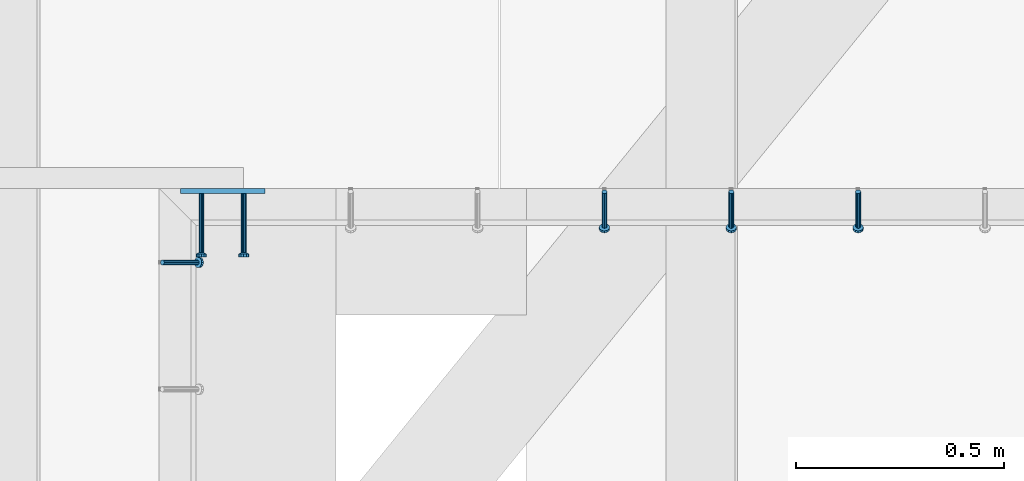
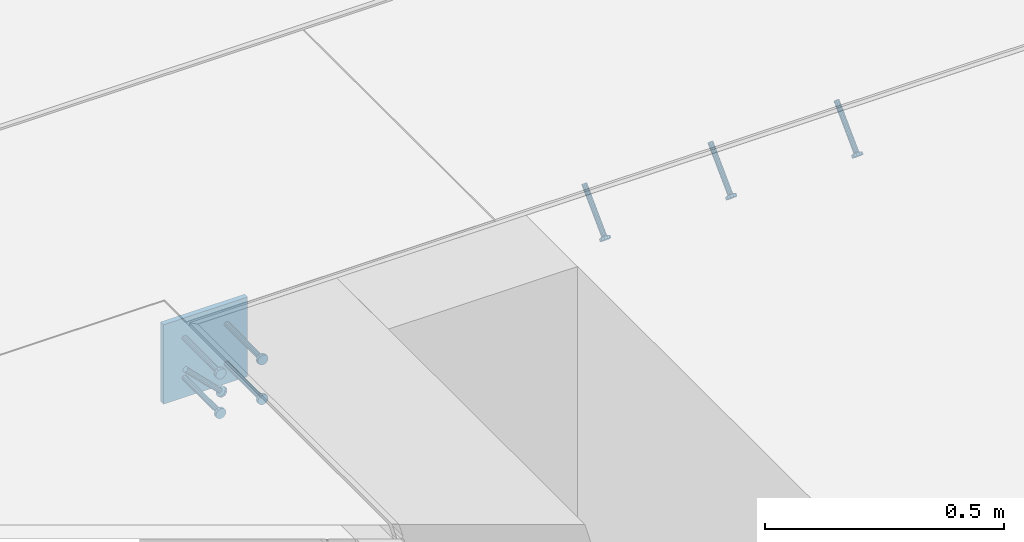
# One storey, part 2517 of 3843: 5 beams, 4 members, 3 elements without a shape of their own.
"""IFC2X3 building model written with IfcOpenShell, lengths in millimetres."""

from ifc_helpers import new_model, si_unit, frame, origin_with_axes, place, context, subcontext, project, spatial, faceted_brep, material, type_object, element, aggregate, save


model = new_model("IFC2X3")

# Units and contexts
model_context = context("Model", 3, precision=1e-05, world=origin_with_axes())
body_context = subcontext(model_context, "Body", "Model", "MODEL_VIEW")
ifc_project = project(units=[si_unit("LENGTHUNIT", "METRE", prefix="MILLI"), si_unit("AREAUNIT", "SQUARE_METRE"), si_unit("VOLUMEUNIT", "CUBIC_METRE"), si_unit("MASSUNIT", "GRAM", prefix="KILO"), si_unit("TIMEUNIT", "SECOND"), si_unit("PLANEANGLEUNIT", "RADIAN"), si_unit("SOLIDANGLEUNIT", "STERADIAN"), si_unit("THERMODYNAMICTEMPERATUREUNIT", "DEGREE_CELSIUS"), si_unit("LUMINOUSINTENSITYUNIT", "LUMEN")], contexts=[model_context])

# Site, building, storey
site_placement = place(None, origin_with_axes())
site = spatial("IfcSite", under=ifc_project, at=site_placement, CompositionType="ELEMENT")
building_placement = place(site_placement, origin_with_axes())
building = spatial("IfcBuilding", under=site, at=building_placement, Name="Undefined", CompositionType="ELEMENT")
storey_placement = place(building_placement, origin_with_axes())
storey = spatial("IfcBuildingStorey", under=building, at=storey_placement, Name="Undefined", CompositionType="ELEMENT", Elevation=0.0)

# Assembly, members
assembly_1_placement = place(storey_placement, origin_with_axes())
assembly_1 = element("IfcElementAssembly", 1, at=assembly_1_placement, inside=storey, Name="EMBED_ANGLE", AssemblyPlace="NOTDEFINED", PredefinedType="RIGID_FRAME")
ifc_material_1 = material(Name="STEEL/A108")
member_type = type_object("IfcMemberType", PredefinedType="NOTDEFINED")
member_1_placement = place(assembly_1_placement, frame((61332.250304107, 90041.2848125, 30446.6625), z_axis=(-1.0, 0.0, 0.0), x_axis=(0.0, -0.707106781186548, -0.707106781186548)))
member_1 = element("IfcMember", 2, at=member_1_placement, type_object=member_type, material=ifc_material_1, Name="HEADED STUD ANCHOR", context=body_context, shape_type="Brep", body=[
    faceted_brep([(7.27595761418343e-12, -3.18000006675175, 5.5), (0.0, -5.49999999998363, 3.1800000667572), (118.110000000976, -5.49999999999091, 3.1800000667572), (118.110000000983, -3.18000006675175, 5.5), (0.0, -6.3499999046162, 0.0), (118.110000000968, -6.34999990461256, 0.0), (0.0, -5.49999999998363, -3.1800000667572), (118.110000000976, -5.49999999999091, -3.1800000667572), (7.27595761418343e-12, -3.18000006675175, -5.5), (118.110000000983, -3.18000006675175, -5.5), (7.27595761418343e-12, -1.81898940354586e-12, -6.34999990463257), (118.110000000968, -1.81898940354586e-12, -6.34999990463257), (0.0, 3.18000006675175, -5.5), (118.110000000968, 3.18000006674811, -5.5), (7.27595761418343e-12, 5.49999999998363, -3.1800000667572), (118.110000000983, 5.49999999998363, -3.1800000667572), (7.27595761418343e-12, 6.3499999046162, 0.0), (118.110000000976, 6.34999990461256, 0.0), (7.27595761418343e-12, 5.49999999998363, 3.1800000667572), (118.110000000983, 5.49999999998363, 3.1800000667572), (0.0, 3.18000006675175, 5.5), (118.110000000968, 3.18000006674811, 5.5), (7.27595761418343e-12, -1.81898940354586e-12, 6.34999990463257), (118.110000000968, -1.81898940354586e-12, 6.34999990463257), (120.650000000991, -10.9899997710909, 6.34999990463257), (120.650000000998, -6.34000015257152, 10.9899997711182), (120.650000000991, -12.6999998092379, 0.0), (120.650000000991, -10.9899997710909, -6.34999990463257), (120.650000000998, -6.34000015257152, -10.9899997711182), (120.650000000991, -1.81898940354586e-12, -12.6899995803833), (120.650000000991, 6.34000015257152, -10.9899997711182), (120.650000000998, 10.9899997710909, -6.34999990463257), (120.650000000991, 12.6999998092342, 0.0), (120.650000000998, 10.9899997710909, 6.34999990463257), (120.650000000991, 6.34000015257152, 10.9899997711182), (120.650000000991, -1.81898940354586e-12, 12.6899995803833), (127.000000001048, -10.9899997710945, 6.34999990463257), (127.000000001048, -6.34000015257152, 10.9899997711182), (127.000000001048, -12.6999998092342, 0.0), (127.000000001048, -10.9899997710945, -6.34999990463257), (127.000000001048, -6.34000015257152, -10.9899997711182), (127.000000001048, 1.81898940354586e-12, -12.6899995803833), (127.000000001048, 6.34000015256788, -10.9899997711182), (127.000000001048, 10.9899997710909, -6.34999990463257), (127.000000001048, 12.6999998092379, 0.0), (127.000000001048, 10.9899997710909, 6.34999990463257), (127.000000001048, 6.34000015256788, 10.9899997711182), (127.000000001048, 1.81898940354586e-12, 12.6899995803833)], [[[0, 1, 2, 3]], [[1, 4, 5, 2]], [[4, 6, 7, 5]], [[6, 8, 9, 7]], [[8, 10, 11, 9]], [[10, 12, 13, 11]], [[12, 14, 15, 13]], [[14, 16, 17, 15]], [[16, 18, 19, 17]], [[18, 20, 21, 19]], [[20, 22, 23, 21]], [[22, 0, 3, 23]], [[22, 20, 18, 16, 14, 12, 10, 8, 6, 4, 1, 0]], [[3, 2, 24, 25]], [[2, 5, 26, 24]], [[5, 7, 27, 26]], [[7, 9, 28, 27]], [[9, 11, 29, 28]], [[11, 13, 30, 29]], [[13, 15, 31, 30]], [[15, 17, 32, 31]], [[17, 19, 33, 32]], [[19, 21, 34, 33]], [[21, 23, 35, 34]], [[23, 3, 25, 35]], [[25, 24, 36, 37]], [[24, 26, 38, 36]], [[26, 27, 39, 38]], [[27, 28, 40, 39]], [[28, 29, 41, 40]], [[29, 30, 42, 41]], [[30, 31, 43, 42]], [[31, 32, 44, 43]], [[32, 33, 45, 44]], [[33, 34, 46, 45]], [[34, 35, 47, 46]], [[35, 25, 37, 47]], [[38, 39, 40, 41, 42, 43, 44, 45, 46, 47, 37, 36]]]),
])
member_2_placement = place(assembly_1_placement, frame((61027.450304107, 90041.2848125, 30446.6625), z_axis=(-1.0, 0.0, 0.0), x_axis=(0.0, -0.707106781186548, -0.707106781186548)))
member_2 = element("IfcMember", 3, at=member_2_placement, type_object=member_type, material=ifc_material_1, Name="HEADED STUD ANCHOR", context=body_context, shape_type="Brep", body=[
    faceted_brep([(7.27595761418343e-12, -3.18000006675175, 5.5), (0.0, -5.49999999998363, 3.1800000667572), (118.110000000976, -5.49999999999091, 3.1800000667572), (118.110000000983, -3.18000006675175, 5.5), (0.0, -6.3499999046162, 0.0), (118.110000000968, -6.34999990461256, 0.0), (0.0, -5.49999999998363, -3.1800000667572), (118.110000000976, -5.49999999999091, -3.1800000667572), (7.27595761418343e-12, -3.18000006675175, -5.5), (118.110000000983, -3.18000006675175, -5.5), (7.27595761418343e-12, -1.81898940354586e-12, -6.34999990463257), (118.110000000968, -1.81898940354586e-12, -6.34999990463257), (0.0, 3.18000006675175, -5.5), (118.110000000968, 3.18000006674811, -5.5), (7.27595761418343e-12, 5.49999999998363, -3.1800000667572), (118.110000000983, 5.49999999998363, -3.1800000667572), (7.27595761418343e-12, 6.3499999046162, 0.0), (118.110000000976, 6.34999990461256, 0.0), (7.27595761418343e-12, 5.49999999998363, 3.1800000667572), (118.110000000983, 5.49999999998363, 3.1800000667572), (0.0, 3.18000006675175, 5.5), (118.110000000968, 3.18000006674811, 5.5), (7.27595761418343e-12, -1.81898940354586e-12, 6.34999990463257), (118.110000000968, -1.81898940354586e-12, 6.34999990463257), (120.650000000991, -10.9899997710909, 6.34999990463257), (120.650000000998, -6.34000015257152, 10.9899997711182), (120.650000000991, -12.6999998092379, 0.0), (120.650000000991, -10.9899997710909, -6.34999990463257), (120.650000000998, -6.34000015257152, -10.9899997711182), (120.650000000991, -1.81898940354586e-12, -12.6899995803833), (120.650000000991, 6.34000015257152, -10.9899997711182), (120.650000000998, 10.9899997710909, -6.34999990463257), (120.650000000991, 12.6999998092342, 0.0), (120.650000000998, 10.9899997710909, 6.34999990463257), (120.650000000991, 6.34000015257152, 10.9899997711182), (120.650000000991, -1.81898940354586e-12, 12.6899995803833), (127.000000001048, -10.9899997710945, 6.34999990463257), (127.000000001048, -6.34000015257152, 10.9899997711182), (127.000000001048, -12.6999998092342, 0.0), (127.000000001048, -10.9899997710945, -6.34999990463257), (127.000000001048, -6.34000015257152, -10.9899997711182), (127.000000001048, 1.81898940354586e-12, -12.6899995803833), (127.000000001048, 6.34000015256788, -10.9899997711182), (127.000000001048, 10.9899997710909, -6.34999990463257), (127.000000001048, 12.6999998092379, 0.0), (127.000000001048, 10.9899997710909, 6.34999990463257), (127.000000001048, 6.34000015256788, 10.9899997711182), (127.000000001048, 1.81898940354586e-12, 12.6899995803833)], [[[0, 1, 2, 3]], [[1, 4, 5, 2]], [[4, 6, 7, 5]], [[6, 8, 9, 7]], [[8, 10, 11, 9]], [[10, 12, 13, 11]], [[12, 14, 15, 13]], [[14, 16, 17, 15]], [[16, 18, 19, 17]], [[18, 20, 21, 19]], [[20, 22, 23, 21]], [[22, 0, 3, 23]], [[22, 20, 18, 16, 14, 12, 10, 8, 6, 4, 1, 0]], [[3, 2, 24, 25]], [[2, 5, 26, 24]], [[5, 7, 27, 26]], [[7, 9, 28, 27]], [[9, 11, 29, 28]], [[11, 13, 30, 29]], [[13, 15, 31, 30]], [[15, 17, 32, 31]], [[17, 19, 33, 32]], [[19, 21, 34, 33]], [[21, 23, 35, 34]], [[23, 3, 25, 35]], [[25, 24, 36, 37]], [[24, 26, 38, 36]], [[26, 27, 39, 38]], [[27, 28, 40, 39]], [[28, 29, 41, 40]], [[29, 30, 42, 41]], [[30, 31, 43, 42]], [[31, 32, 44, 43]], [[32, 33, 45, 44]], [[33, 34, 46, 45]], [[34, 35, 47, 46]], [[35, 25, 37, 47]], [[38, 39, 40, 41, 42, 43, 44, 45, 46, 47, 37, 36]]]),
])
member_3_placement = place(assembly_1_placement, frame((60722.650304107, 90041.2848125, 30446.6625), z_axis=(-1.0, 0.0, 0.0), x_axis=(0.0, -0.707106781186548, -0.707106781186548)))
member_3 = element("IfcMember", 4, at=member_3_placement, type_object=member_type, material=ifc_material_1, Name="HEADED STUD ANCHOR", context=body_context, shape_type="Brep", body=[
    faceted_brep([(7.27595761418343e-12, -3.18000006675175, 5.5), (0.0, -5.49999999998363, 3.1800000667572), (118.110000000976, -5.49999999999091, 3.1800000667572), (118.110000000983, -3.18000006675175, 5.5), (0.0, -6.3499999046162, 0.0), (118.110000000968, -6.34999990461256, 0.0), (0.0, -5.49999999998363, -3.1800000667572), (118.110000000976, -5.49999999999091, -3.1800000667572), (7.27595761418343e-12, -3.18000006675175, -5.5), (118.110000000983, -3.18000006675175, -5.5), (7.27595761418343e-12, -1.81898940354586e-12, -6.34999990463257), (118.110000000968, -1.81898940354586e-12, -6.34999990463257), (0.0, 3.18000006675175, -5.5), (118.110000000968, 3.18000006674811, -5.5), (7.27595761418343e-12, 5.49999999998363, -3.1800000667572), (118.110000000983, 5.49999999998363, -3.1800000667572), (7.27595761418343e-12, 6.3499999046162, 0.0), (118.110000000976, 6.34999990461256, 0.0), (7.27595761418343e-12, 5.49999999998363, 3.1800000667572), (118.110000000983, 5.49999999998363, 3.1800000667572), (0.0, 3.18000006675175, 5.5), (118.110000000968, 3.18000006674811, 5.5), (7.27595761418343e-12, -1.81898940354586e-12, 6.34999990463257), (118.110000000968, -1.81898940354586e-12, 6.34999990463257), (120.650000000991, -10.9899997710909, 6.34999990463257), (120.650000000998, -6.34000015257152, 10.9899997711182), (120.650000000991, -12.6999998092379, 0.0), (120.650000000991, -10.9899997710909, -6.34999990463257), (120.650000000998, -6.34000015257152, -10.9899997711182), (120.650000000991, -1.81898940354586e-12, -12.6899995803833), (120.650000000991, 6.34000015257152, -10.9899997711182), (120.650000000998, 10.9899997710909, -6.34999990463257), (120.650000000991, 12.6999998092342, 0.0), (120.650000000998, 10.9899997710909, 6.34999990463257), (120.650000000991, 6.34000015257152, 10.9899997711182), (120.650000000991, -1.81898940354586e-12, 12.6899995803833), (127.000000001048, -10.9899997710945, 6.34999990463257), (127.000000001048, -6.34000015257152, 10.9899997711182), (127.000000001048, -12.6999998092342, 0.0), (127.000000001048, -10.9899997710945, -6.34999990463257), (127.000000001048, -6.34000015257152, -10.9899997711182), (127.000000001048, 1.81898940354586e-12, -12.6899995803833), (127.000000001048, 6.34000015256788, -10.9899997711182), (127.000000001048, 10.9899997710909, -6.34999990463257), (127.000000001048, 12.6999998092379, 0.0), (127.000000001048, 10.9899997710909, 6.34999990463257), (127.000000001048, 6.34000015256788, 10.9899997711182), (127.000000001048, 1.81898940354586e-12, 12.6899995803833)], [[[0, 1, 2, 3]], [[1, 4, 5, 2]], [[4, 6, 7, 5]], [[6, 8, 9, 7]], [[8, 10, 11, 9]], [[10, 12, 13, 11]], [[12, 14, 15, 13]], [[14, 16, 17, 15]], [[16, 18, 19, 17]], [[18, 20, 21, 19]], [[20, 22, 23, 21]], [[22, 0, 3, 23]], [[22, 20, 18, 16, 14, 12, 10, 8, 6, 4, 1, 0]], [[3, 2, 24, 25]], [[2, 5, 26, 24]], [[5, 7, 27, 26]], [[7, 9, 28, 27]], [[9, 11, 29, 28]], [[11, 13, 30, 29]], [[13, 15, 31, 30]], [[15, 17, 32, 31]], [[17, 19, 33, 32]], [[19, 21, 34, 33]], [[21, 23, 35, 34]], [[23, 3, 25, 35]], [[25, 24, 36, 37]], [[24, 26, 38, 36]], [[26, 27, 39, 38]], [[27, 28, 40, 39]], [[28, 29, 41, 40]], [[29, 30, 42, 41]], [[30, 31, 43, 42]], [[31, 32, 44, 43]], [[32, 33, 45, 44]], [[33, 34, 46, 45]], [[34, 35, 47, 46]], [[35, 25, 37, 47]], [[38, 39, 40, 41, 42, 43, 44, 45, 46, 47, 37, 36]]]),
])
aggregate(assembly_1, [member_1, member_2, member_3])

# Assembly, member
assembly_2_placement = place(storey_placement, origin_with_axes())
assembly_2 = element("IfcElementAssembly", 5, at=assembly_2_placement, inside=storey, Name="EMBED_ANGLE", AssemblyPlace="NOTDEFINED", PredefinedType="RIGID_FRAME")
member_4_placement = place(assembly_2_placement, frame((59660.5996396484, 89871.4223186035, 30446.6625), z_axis=(0.0, 1.0, 0.0), x_axis=(0.707106781186548, 0.0, -0.707106781186548)))
member_4 = element("IfcMember", 6, at=member_4_placement, type_object=member_type, material=ifc_material_1, Name="HEADED STUD ANCHOR", context=body_context, shape_type="Brep", body=[
    faceted_brep([(7.27595761418343e-12, -3.18000006675175, 5.5), (0.0, -5.49999999998363, 3.1800000667572), (118.110000000976, -5.49999999999091, 3.1800000667572), (118.110000000983, -3.18000006675175, 5.5), (0.0, -6.3499999046162, 0.0), (118.110000000968, -6.34999990461256, 0.0), (0.0, -5.49999999998363, -3.1800000667572), (118.110000000976, -5.49999999999091, -3.1800000667572), (7.27595761418343e-12, -3.18000006675175, -5.5), (118.110000000983, -3.18000006675175, -5.5), (7.27595761418343e-12, -1.81898940354586e-12, -6.34999990463257), (118.110000000968, -1.81898940354586e-12, -6.34999990463257), (0.0, 3.18000006675175, -5.5), (118.110000000968, 3.18000006674811, -5.5), (7.27595761418343e-12, 5.49999999998363, -3.1800000667572), (118.110000000983, 5.49999999998363, -3.1800000667572), (7.27595761418343e-12, 6.3499999046162, 0.0), (118.110000000976, 6.34999990461256, 0.0), (7.27595761418343e-12, 5.49999999998363, 3.1800000667572), (118.110000000983, 5.49999999998363, 3.1800000667572), (0.0, 3.18000006675175, 5.5), (118.110000000968, 3.18000006674811, 5.5), (7.27595761418343e-12, -1.81898940354586e-12, 6.34999990463257), (118.110000000968, -1.81898940354586e-12, 6.34999990463257), (120.650000000991, -10.9899997710909, 6.34999990463257), (120.650000000998, -6.34000015257152, 10.9899997711182), (120.650000000991, -12.6999998092379, 0.0), (120.650000000991, -10.9899997710909, -6.34999990463257), (120.650000000998, -6.34000015257152, -10.9899997711182), (120.650000000991, -1.81898940354586e-12, -12.6899995803833), (120.650000000991, 6.34000015257152, -10.9899997711182), (120.650000000998, 10.9899997710909, -6.34999990463257), (120.650000000991, 12.6999998092342, 0.0), (120.650000000998, 10.9899997710909, 6.34999990463257), (120.650000000991, 6.34000015257152, 10.9899997711182), (120.650000000991, -1.81898940354586e-12, 12.6899995803833), (127.000000001048, -10.9899997710945, 6.34999990463257), (127.000000001048, -6.34000015257152, 10.9899997711182), (127.000000001048, -12.6999998092342, 0.0), (127.000000001048, -10.9899997710945, -6.34999990463257), (127.000000001048, -6.34000015257152, -10.9899997711182), (127.000000001048, 1.81898940354586e-12, -12.6899995803833), (127.000000001048, 6.34000015256788, -10.9899997711182), (127.000000001048, 10.9899997710909, -6.34999990463257), (127.000000001048, 12.6999998092379, 0.0), (127.000000001048, 10.9899997710909, 6.34999990463257), (127.000000001048, 6.34000015256788, 10.9899997711182), (127.000000001048, 1.81898940354586e-12, 12.6899995803833)], [[[0, 1, 2, 3]], [[1, 4, 5, 2]], [[4, 6, 7, 5]], [[6, 8, 9, 7]], [[8, 10, 11, 9]], [[10, 12, 13, 11]], [[12, 14, 15, 13]], [[14, 16, 17, 15]], [[16, 18, 19, 17]], [[18, 20, 21, 19]], [[20, 22, 23, 21]], [[22, 0, 3, 23]], [[22, 20, 18, 16, 14, 12, 10, 8, 6, 4, 1, 0]], [[3, 2, 24, 25]], [[2, 5, 26, 24]], [[5, 7, 27, 26]], [[7, 9, 28, 27]], [[9, 11, 29, 28]], [[11, 13, 30, 29]], [[13, 15, 31, 30]], [[15, 17, 32, 31]], [[17, 19, 33, 32]], [[19, 21, 34, 33]], [[21, 23, 35, 34]], [[23, 3, 25, 35]], [[25, 24, 36, 37]], [[24, 26, 38, 36]], [[26, 27, 39, 38]], [[27, 28, 40, 39]], [[28, 29, 41, 40]], [[29, 30, 42, 41]], [[30, 31, 43, 42]], [[31, 32, 44, 43]], [[32, 33, 45, 44]], [[33, 34, 46, 45]], [[34, 35, 47, 46]], [[35, 25, 37, 47]], [[38, 39, 40, 41, 42, 43, 44, 45, 46, 47, 37, 36]]]),
])
aggregate(assembly_2, [member_4])

# Assembly, beams
assembly_3_placement = place(storey_placement, origin_with_axes())
assembly_3 = element("IfcElementAssembly", 7, at=assembly_3_placement, inside=storey, Name="EMBED PLATE", AssemblyPlace="NOTDEFINED", PredefinedType="RIGID_FRAME")
ifc_material_2 = material(Name="STEEL/A36")
beam_type_1 = type_object("IfcBeamType", PredefinedType="NOTDEFINED")
beam_1_placement = place(assembly_3_placement, frame((59805.0619999963, 90042.8723827029, 30445.075), z_axis=(-1.0, 0.0, 0.0), x_axis=(0.0, 0.0, -1.0)))
beam_1 = element("IfcBeam", 8, at=beam_1_placement, type_object=beam_type_1, material=ifc_material_2, Name="EMBED PLATE", context=body_context, shape_type="Brep", body=[
    faceted_brep([(1.74622982740402e-10, 6.35000000000582, -101.600000000195), (-1.67347025126219e-10, 6.35000000000582, 101.600000000151), (203.200000000001, 6.35000000000582, 101.599999999999), (203.200000000001, 6.35000000000582, -101.599999999999), (-1.67347025126219e-10, -6.35000000000582, 101.600000000151), (203.200000000001, -6.35000000000582, 101.599999999999), (1.74622982740402e-10, -6.35000000000582, -101.600000000195), (203.200000000001, -6.35000000000582, -101.599999999999)], [[[0, 1, 2, 3]], [[1, 4, 5, 2]], [[4, 6, 7, 5]], [[6, 0, 3, 7]], [[5, 7, 3, 2]], [[6, 4, 1, 0]]]),
])
beam_type_2 = type_object("IfcBeamType", PredefinedType="NOTDEFINED")
beam_2_placement = place(assembly_3_placement, frame((59855.8619999963, 90036.522382703, 30394.275), z_axis=(1.0, 0.0, 0.0), x_axis=(0.0, -1.0, 0.0)))
beam_2 = element("IfcBeam", 9, at=beam_2_placement, type_object=beam_type_2, material=ifc_material_1, Name="HEADED STUD ANCHOR", context=body_context, shape_type="Brep", body=[
    faceted_brep([(7.27595761418343e-12, -3.18000006675175, 5.5), (0.0, -5.49999999998363, 3.1800000667572), (141.731999999989, -5.5, 3.1800000667572), (141.731999999989, -3.1800000667572, 5.5), (0.0, -6.3499999046162, 0.0), (141.731999999989, -6.34999990463257, 0.0), (0.0, -5.49999999998363, -3.1800000667572), (141.731999999989, -5.5, -3.1800000667572), (7.27595761418343e-12, -3.18000006675175, -5.5), (141.731999999989, -3.1800000667572, -5.5), (7.27595761418343e-12, -1.81898940354586e-12, -6.34999990463257), (141.731999999989, 0.0, -6.34999990463257), (0.0, 3.18000006675175, -5.5), (141.731999999989, 3.1800000667572, -5.5), (7.27595761418343e-12, 5.49999999998363, -3.1800000667572), (141.731999999989, 5.5, -3.1800000667572), (7.27595761418343e-12, 6.3499999046162, 0.0), (141.731999999989, 6.34999990463257, 0.0), (7.27595761418343e-12, 5.49999999998363, 3.1800000667572), (141.731999999989, 5.5, 3.1800000667572), (0.0, 3.18000006675175, 5.5), (141.731999999989, 3.1800000667572, 5.5), (7.27595761418343e-12, -1.81898940354586e-12, 6.34999990463257), (141.731999999989, 0.0, 6.34999990463257), (144.779999999999, -10.9899997711182, 6.34999990463257), (144.779999999999, -6.34000015258789, 10.9899997711182), (144.779999999999, -12.6999998092651, 0.0), (144.779999999999, -10.9899997711182, -6.34999990463257), (144.779999999999, -6.34000015258789, -10.9899997711182), (144.779999999999, 0.0, -12.6899995803833), (144.779999999999, 6.34000015258789, -10.9899997711182), (144.779999999999, 10.9899997711182, -6.34999990463257), (144.779999999999, 12.6999998092651, 0.0), (144.779999999999, 10.9899997711182, 6.34999990463257), (144.779999999999, 6.34000015258789, 10.9899997711182), (144.779999999999, 0.0, 12.6899995803833), (152.399999999994, -10.9899997711182, 6.34999990463257), (152.399999999994, -6.34000015258789, 10.9899997711182), (152.399999999994, -12.6999998092651, 0.0), (152.399999999994, -10.9899997711182, -6.34999990463257), (152.399999999994, -6.34000015258789, -10.9899997711182), (152.399999999994, 0.0, -12.6899995803833), (152.399999999994, 6.34000015258789, -10.9899997711182), (152.399999999994, 10.9899997711182, -6.34999990463257), (152.399999999994, 12.6999998092651, 0.0), (152.399999999994, 10.9899997711182, 6.34999990463257), (152.399999999994, 6.34000015258789, 10.9899997711182), (152.399999999994, 0.0, 12.6899995803833)], [[[0, 1, 2, 3]], [[1, 4, 5, 2]], [[4, 6, 7, 5]], [[6, 8, 9, 7]], [[8, 10, 11, 9]], [[10, 12, 13, 11]], [[12, 14, 15, 13]], [[14, 16, 17, 15]], [[16, 18, 19, 17]], [[18, 20, 21, 19]], [[20, 22, 23, 21]], [[22, 0, 3, 23]], [[22, 20, 18, 16, 14, 12, 10, 8, 6, 4, 1, 0]], [[3, 2, 24, 25]], [[2, 5, 26, 24]], [[5, 7, 27, 26]], [[7, 9, 28, 27]], [[9, 11, 29, 28]], [[11, 13, 30, 29]], [[13, 15, 31, 30]], [[15, 17, 32, 31]], [[17, 19, 33, 32]], [[19, 21, 34, 33]], [[21, 23, 35, 34]], [[23, 3, 25, 35]], [[25, 24, 36, 37]], [[24, 26, 38, 36]], [[26, 27, 39, 38]], [[27, 28, 40, 39]], [[28, 29, 41, 40]], [[29, 30, 42, 41]], [[30, 31, 43, 42]], [[31, 32, 44, 43]], [[32, 33, 45, 44]], [[33, 34, 46, 45]], [[34, 35, 47, 46]], [[35, 25, 37, 47]], [[38, 39, 40, 41, 42, 43, 44, 45, 46, 47, 37, 36]]]),
])
beam_3_placement = place(assembly_3_placement, frame((59855.8619999963, 90036.522382703, 30292.675), z_axis=(1.0, 0.0, 0.0), x_axis=(0.0, -1.0, 0.0)))
beam_3 = element("IfcBeam", 10, at=beam_3_placement, type_object=beam_type_2, material=ifc_material_1, Name="HEADED STUD ANCHOR", context=body_context, shape_type="Brep", body=[
    faceted_brep([(7.27595761418343e-12, -3.18000006675175, 5.5), (0.0, -5.49999999998363, 3.1800000667572), (141.731999999989, -5.5, 3.1800000667572), (141.731999999989, -3.1800000667572, 5.5), (0.0, -6.3499999046162, 0.0), (141.731999999989, -6.34999990463257, 0.0), (0.0, -5.49999999998363, -3.1800000667572), (141.731999999989, -5.5, -3.1800000667572), (7.27595761418343e-12, -3.18000006675175, -5.5), (141.731999999989, -3.1800000667572, -5.5), (7.27595761418343e-12, -1.81898940354586e-12, -6.34999990463257), (141.731999999989, 0.0, -6.34999990463257), (0.0, 3.18000006675175, -5.5), (141.731999999989, 3.1800000667572, -5.5), (7.27595761418343e-12, 5.49999999998363, -3.1800000667572), (141.731999999989, 5.5, -3.1800000667572), (7.27595761418343e-12, 6.3499999046162, 0.0), (141.731999999989, 6.34999990463257, 0.0), (7.27595761418343e-12, 5.49999999998363, 3.1800000667572), (141.731999999989, 5.5, 3.1800000667572), (0.0, 3.18000006675175, 5.5), (141.731999999989, 3.1800000667572, 5.5), (7.27595761418343e-12, -1.81898940354586e-12, 6.34999990463257), (141.731999999989, 0.0, 6.34999990463257), (144.779999999999, -10.9899997711182, 6.34999990463257), (144.779999999999, -6.34000015258789, 10.9899997711182), (144.779999999999, -12.6999998092651, 0.0), (144.779999999999, -10.9899997711182, -6.34999990463257), (144.779999999999, -6.34000015258789, -10.9899997711182), (144.779999999999, 0.0, -12.6899995803833), (144.779999999999, 6.34000015258789, -10.9899997711182), (144.779999999999, 10.9899997711182, -6.34999990463257), (144.779999999999, 12.6999998092651, 0.0), (144.779999999999, 10.9899997711182, 6.34999990463257), (144.779999999999, 6.34000015258789, 10.9899997711182), (144.779999999999, 0.0, 12.6899995803833), (152.399999999994, -10.9899997711182, 6.34999990463257), (152.399999999994, -6.34000015258789, 10.9899997711182), (152.399999999994, -12.6999998092651, 0.0), (152.399999999994, -10.9899997711182, -6.34999990463257), (152.399999999994, -6.34000015258789, -10.9899997711182), (152.399999999994, 0.0, -12.6899995803833), (152.399999999994, 6.34000015258789, -10.9899997711182), (152.399999999994, 10.9899997711182, -6.34999990463257), (152.399999999994, 12.6999998092651, 0.0), (152.399999999994, 10.9899997711182, 6.34999990463257), (152.399999999994, 6.34000015258789, 10.9899997711182), (152.399999999994, 0.0, 12.6899995803833)], [[[0, 1, 2, 3]], [[1, 4, 5, 2]], [[4, 6, 7, 5]], [[6, 8, 9, 7]], [[8, 10, 11, 9]], [[10, 12, 13, 11]], [[12, 14, 15, 13]], [[14, 16, 17, 15]], [[16, 18, 19, 17]], [[18, 20, 21, 19]], [[20, 22, 23, 21]], [[22, 0, 3, 23]], [[22, 20, 18, 16, 14, 12, 10, 8, 6, 4, 1, 0]], [[3, 2, 24, 25]], [[2, 5, 26, 24]], [[5, 7, 27, 26]], [[7, 9, 28, 27]], [[9, 11, 29, 28]], [[11, 13, 30, 29]], [[13, 15, 31, 30]], [[15, 17, 32, 31]], [[17, 19, 33, 32]], [[19, 21, 34, 33]], [[21, 23, 35, 34]], [[23, 3, 25, 35]], [[25, 24, 36, 37]], [[24, 26, 38, 36]], [[26, 27, 39, 38]], [[27, 28, 40, 39]], [[28, 29, 41, 40]], [[29, 30, 42, 41]], [[30, 31, 43, 42]], [[31, 32, 44, 43]], [[32, 33, 45, 44]], [[33, 34, 46, 45]], [[34, 35, 47, 46]], [[35, 25, 37, 47]], [[38, 39, 40, 41, 42, 43, 44, 45, 46, 47, 37, 36]]]),
])
beam_4_placement = place(assembly_3_placement, frame((59754.2619999963, 90036.522382703, 30394.275), z_axis=(1.0, 0.0, 0.0), x_axis=(0.0, -1.0, 0.0)))
beam_4 = element("IfcBeam", 11, at=beam_4_placement, type_object=beam_type_2, material=ifc_material_1, Name="HEADED STUD ANCHOR", context=body_context, shape_type="Brep", body=[
    faceted_brep([(7.27595761418343e-12, -3.18000006675175, 5.5), (0.0, -5.49999999998363, 3.1800000667572), (141.731999999989, -5.5, 3.1800000667572), (141.731999999989, -3.1800000667572, 5.5), (0.0, -6.3499999046162, 0.0), (141.731999999989, -6.34999990463257, 0.0), (0.0, -5.49999999998363, -3.1800000667572), (141.731999999989, -5.5, -3.1800000667572), (7.27595761418343e-12, -3.18000006675175, -5.5), (141.731999999989, -3.1800000667572, -5.5), (7.27595761418343e-12, -1.81898940354586e-12, -6.34999990463257), (141.731999999989, 0.0, -6.34999990463257), (0.0, 3.18000006675175, -5.5), (141.731999999989, 3.1800000667572, -5.5), (7.27595761418343e-12, 5.49999999998363, -3.1800000667572), (141.731999999989, 5.5, -3.1800000667572), (7.27595761418343e-12, 6.3499999046162, 0.0), (141.731999999989, 6.34999990463257, 0.0), (7.27595761418343e-12, 5.49999999998363, 3.1800000667572), (141.731999999989, 5.5, 3.1800000667572), (0.0, 3.18000006675175, 5.5), (141.731999999989, 3.1800000667572, 5.5), (7.27595761418343e-12, -1.81898940354586e-12, 6.34999990463257), (141.731999999989, 0.0, 6.34999990463257), (144.779999999999, -10.9899997711182, 6.34999990463257), (144.779999999999, -6.34000015258789, 10.9899997711182), (144.779999999999, -12.6999998092651, 0.0), (144.779999999999, -10.9899997711182, -6.34999990463257), (144.779999999999, -6.34000015258789, -10.9899997711182), (144.779999999999, 0.0, -12.6899995803833), (144.779999999999, 6.34000015258789, -10.9899997711182), (144.779999999999, 10.9899997711182, -6.34999990463257), (144.779999999999, 12.6999998092651, 0.0), (144.779999999999, 10.9899997711182, 6.34999990463257), (144.779999999999, 6.34000015258789, 10.9899997711182), (144.779999999999, 0.0, 12.6899995803833), (152.399999999994, -10.9899997711182, 6.34999990463257), (152.399999999994, -6.34000015258789, 10.9899997711182), (152.399999999994, -12.6999998092651, 0.0), (152.399999999994, -10.9899997711182, -6.34999990463257), (152.399999999994, -6.34000015258789, -10.9899997711182), (152.399999999994, 0.0, -12.6899995803833), (152.399999999994, 6.34000015258789, -10.9899997711182), (152.399999999994, 10.9899997711182, -6.34999990463257), (152.399999999994, 12.6999998092651, 0.0), (152.399999999994, 10.9899997711182, 6.34999990463257), (152.399999999994, 6.34000015258789, 10.9899997711182), (152.399999999994, 0.0, 12.6899995803833)], [[[0, 1, 2, 3]], [[1, 4, 5, 2]], [[4, 6, 7, 5]], [[6, 8, 9, 7]], [[8, 10, 11, 9]], [[10, 12, 13, 11]], [[12, 14, 15, 13]], [[14, 16, 17, 15]], [[16, 18, 19, 17]], [[18, 20, 21, 19]], [[20, 22, 23, 21]], [[22, 0, 3, 23]], [[22, 20, 18, 16, 14, 12, 10, 8, 6, 4, 1, 0]], [[3, 2, 24, 25]], [[2, 5, 26, 24]], [[5, 7, 27, 26]], [[7, 9, 28, 27]], [[9, 11, 29, 28]], [[11, 13, 30, 29]], [[13, 15, 31, 30]], [[15, 17, 32, 31]], [[17, 19, 33, 32]], [[19, 21, 34, 33]], [[21, 23, 35, 34]], [[23, 3, 25, 35]], [[25, 24, 36, 37]], [[24, 26, 38, 36]], [[26, 27, 39, 38]], [[27, 28, 40, 39]], [[28, 29, 41, 40]], [[29, 30, 42, 41]], [[30, 31, 43, 42]], [[31, 32, 44, 43]], [[32, 33, 45, 44]], [[33, 34, 46, 45]], [[34, 35, 47, 46]], [[35, 25, 37, 47]], [[38, 39, 40, 41, 42, 43, 44, 45, 46, 47, 37, 36]]]),
])
beam_5_placement = place(assembly_3_placement, frame((59754.2619999963, 90036.522382703, 30292.675), z_axis=(1.0, 0.0, 0.0), x_axis=(0.0, -1.0, 0.0)))
beam_5 = element("IfcBeam", 12, at=beam_5_placement, type_object=beam_type_2, material=ifc_material_1, Name="HEADED STUD ANCHOR", context=body_context, shape_type="Brep", body=[
    faceted_brep([(7.27595761418343e-12, -3.18000006675175, 5.5), (0.0, -5.49999999998363, 3.1800000667572), (141.731999999989, -5.5, 3.1800000667572), (141.731999999989, -3.1800000667572, 5.5), (0.0, -6.3499999046162, 0.0), (141.731999999989, -6.34999990463257, 0.0), (0.0, -5.49999999998363, -3.1800000667572), (141.731999999989, -5.5, -3.1800000667572), (7.27595761418343e-12, -3.18000006675175, -5.5), (141.731999999989, -3.1800000667572, -5.5), (7.27595761418343e-12, -1.81898940354586e-12, -6.34999990463257), (141.731999999989, 0.0, -6.34999990463257), (0.0, 3.18000006675175, -5.5), (141.731999999989, 3.1800000667572, -5.5), (7.27595761418343e-12, 5.49999999998363, -3.1800000667572), (141.731999999989, 5.5, -3.1800000667572), (7.27595761418343e-12, 6.3499999046162, 0.0), (141.731999999989, 6.34999990463257, 0.0), (7.27595761418343e-12, 5.49999999998363, 3.1800000667572), (141.731999999989, 5.5, 3.1800000667572), (0.0, 3.18000006675175, 5.5), (141.731999999989, 3.1800000667572, 5.5), (7.27595761418343e-12, -1.81898940354586e-12, 6.34999990463257), (141.731999999989, 0.0, 6.34999990463257), (144.779999999999, -10.9899997711182, 6.34999990463257), (144.779999999999, -6.34000015258789, 10.9899997711182), (144.779999999999, -12.6999998092651, 0.0), (144.779999999999, -10.9899997711182, -6.34999990463257), (144.779999999999, -6.34000015258789, -10.9899997711182), (144.779999999999, 0.0, -12.6899995803833), (144.779999999999, 6.34000015258789, -10.9899997711182), (144.779999999999, 10.9899997711182, -6.34999990463257), (144.779999999999, 12.6999998092651, 0.0), (144.779999999999, 10.9899997711182, 6.34999990463257), (144.779999999999, 6.34000015258789, 10.9899997711182), (144.779999999999, 0.0, 12.6899995803833), (152.399999999994, -10.9899997711182, 6.34999990463257), (152.399999999994, -6.34000015258789, 10.9899997711182), (152.399999999994, -12.6999998092651, 0.0), (152.399999999994, -10.9899997711182, -6.34999990463257), (152.399999999994, -6.34000015258789, -10.9899997711182), (152.399999999994, 0.0, -12.6899995803833), (152.399999999994, 6.34000015258789, -10.9899997711182), (152.399999999994, 10.9899997711182, -6.34999990463257), (152.399999999994, 12.6999998092651, 0.0), (152.399999999994, 10.9899997711182, 6.34999990463257), (152.399999999994, 6.34000015258789, 10.9899997711182), (152.399999999994, 0.0, 12.6899995803833)], [[[0, 1, 2, 3]], [[1, 4, 5, 2]], [[4, 6, 7, 5]], [[6, 8, 9, 7]], [[8, 10, 11, 9]], [[10, 12, 13, 11]], [[12, 14, 15, 13]], [[14, 16, 17, 15]], [[16, 18, 19, 17]], [[18, 20, 21, 19]], [[20, 22, 23, 21]], [[22, 0, 3, 23]], [[22, 20, 18, 16, 14, 12, 10, 8, 6, 4, 1, 0]], [[3, 2, 24, 25]], [[2, 5, 26, 24]], [[5, 7, 27, 26]], [[7, 9, 28, 27]], [[9, 11, 29, 28]], [[11, 13, 30, 29]], [[13, 15, 31, 30]], [[15, 17, 32, 31]], [[17, 19, 33, 32]], [[19, 21, 34, 33]], [[21, 23, 35, 34]], [[23, 3, 25, 35]], [[25, 24, 36, 37]], [[24, 26, 38, 36]], [[26, 27, 39, 38]], [[27, 28, 40, 39]], [[28, 29, 41, 40]], [[29, 30, 42, 41]], [[30, 31, 43, 42]], [[31, 32, 44, 43]], [[32, 33, 45, 44]], [[33, 34, 46, 45]], [[34, 35, 47, 46]], [[35, 25, 37, 47]], [[38, 39, 40, 41, 42, 43, 44, 45, 46, 47, 37, 36]]]),
])
aggregate(assembly_3, [beam_2, beam_3, beam_4, beam_5, beam_1])

save(model, "model.ifc")
